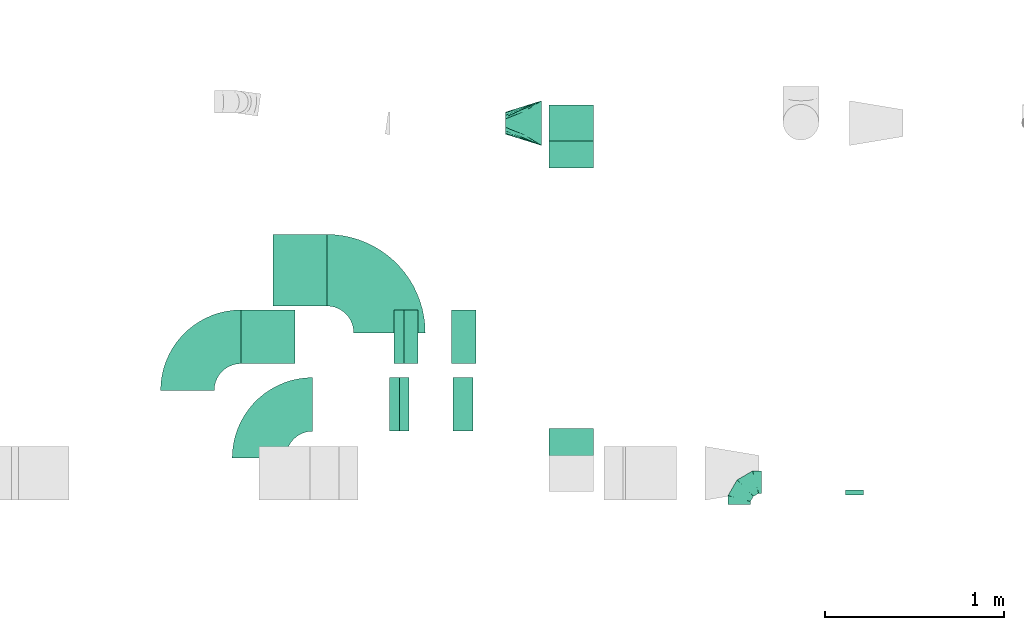
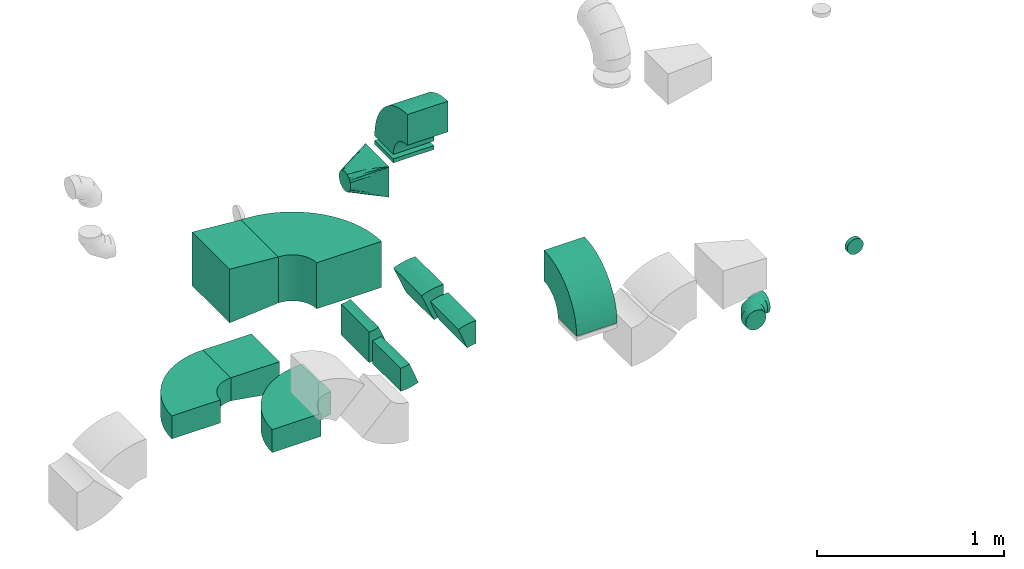
# One storey, part 20 of 44: 15 flow fittings.
"""IFC2X3 building model written with IfcOpenShell, lengths in millimetres."""

from ifc_helpers import new_model, entity, si_unit, converted_unit, derived_unit, direction, frame, frame_2d, origin, origin_2d_with_axis, place, context, subcontext, project, spatial, polyline, circle_curve, parameter, trimmed, segment, composite_curve, rectangle, outline, extrude, faceted_brep, source, transform, mapped, material, type_object, type_shapes, element, save


model = new_model("IFC2X3")

# Units and contexts
model_context = context("Model", 3, precision=0.01, world=origin(), true_north=direction((6.12303176911189e-17, 1.0)))
body_context = subcontext(model_context, "Body", "Model", "MODEL_VIEW")
ifc_project = project(units=[si_unit("LENGTHUNIT", "METRE", prefix="MILLI"), si_unit("AREAUNIT", "SQUARE_METRE"), si_unit("VOLUMEUNIT", "CUBIC_METRE"), converted_unit("PLANEANGLEUNIT", "DEGREE", entity("IfcRatioMeasure", 0.0174532925199433), si_unit("PLANEANGLEUNIT", "RADIAN"), dimensions=[0, 0, 0, 0, 0, 0, 0]), si_unit("MASSUNIT", "GRAM", prefix="KILO"), derived_unit("MASSDENSITYUNIT", [(si_unit("MASSUNIT", "GRAM", prefix="KILO"), 1), (si_unit("LENGTHUNIT", "METRE"), -3)]), derived_unit("MOMENTOFINERTIAUNIT", [(si_unit("LENGTHUNIT", "METRE"), 4)]), si_unit("TIMEUNIT", "SECOND"), si_unit("FREQUENCYUNIT", "HERTZ"), si_unit("THERMODYNAMICTEMPERATUREUNIT", "DEGREE_CELSIUS"), derived_unit("THERMALTRANSMITTANCEUNIT", [(si_unit("MASSUNIT", "GRAM", prefix="KILO"), 1), (si_unit("THERMODYNAMICTEMPERATUREUNIT", "KELVIN"), -1), (si_unit("TIMEUNIT", "SECOND"), -3)]), derived_unit("VOLUMETRICFLOWRATEUNIT", [(si_unit("LENGTHUNIT", "METRE"), 3), (si_unit("TIMEUNIT", "SECOND"), -1)]), derived_unit("MASSFLOWRATEUNIT", [(si_unit("MASSUNIT", "GRAM", prefix="KILO"), 1), (si_unit("TIMEUNIT", "SECOND"), -1)]), derived_unit("ROTATIONALFREQUENCYUNIT", [(si_unit("TIMEUNIT", "SECOND"), -1)]), si_unit("ELECTRICCURRENTUNIT", "AMPERE"), si_unit("ELECTRICVOLTAGEUNIT", "VOLT"), si_unit("POWERUNIT", "WATT"), si_unit("FORCEUNIT", "NEWTON", prefix="KILO"), si_unit("ILLUMINANCEUNIT", "LUX"), si_unit("LUMINOUSFLUXUNIT", "LUMEN"), si_unit("LUMINOUSINTENSITYUNIT", "CANDELA"), derived_unit("USERDEFINED", [(si_unit("MASSUNIT", "GRAM", prefix="KILO"), -1), (si_unit("LENGTHUNIT", "METRE"), -2), (si_unit("TIMEUNIT", "SECOND"), 3), (si_unit("LUMINOUSFLUXUNIT", "LUMEN"), 1)]), derived_unit("LINEARVELOCITYUNIT", [(si_unit("LENGTHUNIT", "METRE"), 1), (si_unit("TIMEUNIT", "SECOND"), -1)]), si_unit("PRESSUREUNIT", "PASCAL"), derived_unit("USERDEFINED", [(si_unit("LENGTHUNIT", "METRE"), -2), (si_unit("MASSUNIT", "GRAM", prefix="KILO"), 1), (si_unit("TIMEUNIT", "SECOND"), -2)]), derived_unit("LINEARFORCEUNIT", [(si_unit("MASSUNIT", "GRAM", prefix="KILO"), 1), (si_unit("LENGTHUNIT", "METRE"), 1), (si_unit("TIMEUNIT", "SECOND"), -2), (si_unit("LENGTHUNIT", "METRE"), -1)]), derived_unit("PLANARFORCEUNIT", [(si_unit("MASSUNIT", "GRAM", prefix="KILO"), 1), (si_unit("LENGTHUNIT", "METRE"), 1), (si_unit("TIMEUNIT", "SECOND"), -2), (si_unit("LENGTHUNIT", "METRE"), -2)])], contexts=[model_context])

# Site, building, storey
site_placement = place(None, origin())
site = spatial("IfcSite", under=ifc_project, at=site_placement, CompositionType="ELEMENT")
building_placement = place(site_placement, origin())
building = spatial("IfcBuilding", under=site, at=building_placement, CompositionType="ELEMENT")
storey_placement = place(building_placement, frame((0.0, 0.0, 15900.0)))
storey = spatial("IfcBuildingStorey", under=building, at=storey_placement, CompositionType="ELEMENT", Elevation=15900.0)

# Flow fittings
ifc_material = material()
duct_fitting_type_1 = type_object("IfcDuctFittingType", PredefinedType="NOTDEFINED", material=ifc_material)
shared_shape_1 = source(origin(), body_context, "Body", "SweptSolid", [
    extrude(outline(polyline([(-150.0, -87.5), (150.0, -87.5), (150.0, 62.5), (-150.0, 112.5), (-150.0, -87.5)])), frame((150.0, -150.0, 12.5), z_axis=(0.0, 1.0, 0.0), x_axis=(1.0, 0.0, 0.0)), (0.0, 0.0, 1.0), 300.0),
])
type_shapes(duct_fitting_type_1, [shared_shape_1])
flow_fitting_1_placement = place(storey_placement, frame((37920.11, 14938.36, 2900.0), z_axis=(0.0, 0.0, 1.0), x_axis=(-1.0, 0.0, 0.0)))
element("IfcFlowFitting", 1, at=flow_fitting_1_placement, inside=storey, type_object=duct_fitting_type_1, material=ifc_material, context=body_context, shape_type="MappedRepresentation", body=[
    mapped(shared_shape_1, transform((0.0, 0.0, 0.0), scale=1.0)),
])
duct_fitting_type_2 = type_object("IfcDuctFittingType", PredefinedType="NOTDEFINED", material=ifc_material)
shared_shape_2 = source(origin(), body_context, "Body", "SweptSolid", [
    extrude(rectangle(XDim=26.096000000009, YDim=250.0, at=origin_2d_with_axis()), frame((6.95, 0.0, -100.0)), (0.0, 0.0, 1.0), 200.0),
])
type_shapes(duct_fitting_type_2, [shared_shape_2])
flow_fitting_2_placement = place(storey_placement, frame((39464.82, 16131.71, 3050.0), z_axis=(0.0, 1.0, 0.0), x_axis=(0.0, 0.0, 1.0)))
element("IfcFlowFitting", 2, at=flow_fitting_2_placement, inside=storey, type_object=duct_fitting_type_2, material=ifc_material, context=body_context, shape_type="MappedRepresentation", body=[
    mapped(shared_shape_2, transform((0.0, 0.0, 0.0), scale=1.0)),
])
duct_fitting_type_3 = type_object("IfcDuctFittingType", PredefinedType="NOTDEFINED", material=ifc_material)
shared_shape_3 = source(origin(), body_context, "Body", "SweptSolid", [
    extrude(outline(polyline([(-137.03, -161.94), (164.01, -161.94), (134.95, 186.85), (-161.94, 137.03), (-137.03, -161.94)])), frame((150.0, -200.0, 0.0), z_axis=(0.0, 1.0, 0.0), x_axis=(0.996545758244888, 0.0, 0.0830454798536443)), (0.0, 0.0, 1.0), 400.0),
])
type_shapes(duct_fitting_type_3, [shared_shape_3])
flow_fitting_3_placement = place(storey_placement, frame((38098.74, 15310.0, 3275.0), z_axis=(0.0, 0.0, 1.0), x_axis=(-1.0, 0.0, 0.0)))
element("IfcFlowFitting", 3, at=flow_fitting_3_placement, inside=storey, type_object=duct_fitting_type_3, material=ifc_material, context=body_context, shape_type="MappedRepresentation", body=[
    mapped(shared_shape_3, transform((0.0, 0.0, 0.0), scale=1.0)),
])
duct_fitting_type_4 = type_object("IfcDuctFittingType", PredefinedType="NOTDEFINED", material=ifc_material)
shared_shape_4 = source(origin(), body_context, "Body", "Brep", [
    faceted_brep([(-125.0, 0.0, -62.5), (-125.0, -16.18, -60.37), (-125.0, -31.25, -54.13), (-125.0, -44.19, -44.19), (-125.0, -54.13, -31.25), (-125.0, -60.37, -16.18), (-125.0, -62.5, 0.0), (-125.0, -60.37, 16.18), (-125.0, -54.13, 31.25), (-125.0, -44.19, 44.19), (-125.0, -31.25, 54.13), (-125.0, -16.18, 60.37), (-125.0, 0.0, 62.5), (-125.0, 16.18, 60.37), (-125.0, 31.25, 54.13), (-125.0, 44.19, 44.19), (-125.0, 54.13, 31.25), (-125.0, 60.37, 16.18), (-125.0, 62.5, 0.0), (-125.0, 60.37, -16.18), (-125.0, 54.13, -31.25), (-125.0, 44.19, -44.19), (-125.0, 31.25, -54.13), (-125.0, 16.18, -60.37), (-95.84, 16.18, 60.37), (-99.88, 31.25, 54.13), (-91.51, 0.0, 62.5), (-103.35, 44.19, 44.19), (-107.68, 60.37, 16.18), (-108.25, 62.5, 0.0), (-106.01, 54.13, 31.25), (-106.01, 54.13, -31.25), (-103.35, 44.19, -44.19), (-107.68, 60.37, -16.18), (-95.84, 16.18, -60.37), (-91.51, 0.0, -62.5), (-99.88, 31.25, -54.13), (-87.17, -16.18, -60.37), (-83.13, -31.25, -54.13), (-79.66, -44.19, -44.19), (-77.0, -54.13, -31.25), (-75.33, -60.37, -16.18), (-74.76, -62.5, 0.0), (-75.33, -60.37, 16.18), (-77.0, -54.13, 31.25), (-79.66, -44.19, 44.19), (-83.13, -31.25, 54.13), (-87.17, -16.18, 60.37), (-45.34, 45.34, 60.37), (-56.37, 56.37, 54.13), (-33.49, 33.49, 62.5), (-65.85, 65.85, 44.19), (-73.12, 73.12, 31.25), (-77.69, 77.69, 16.18), (-79.25, 79.25, 0.0), (-77.69, 77.69, -16.18), (-73.12, 73.12, -31.25), (-65.85, 65.85, -44.19), (-45.34, 45.34, -60.37), (-33.49, 33.49, -62.5), (-56.37, 56.37, -54.13), (-21.65, 21.65, -60.37), (-10.62, 10.62, -54.13), (-1.14, 1.14, -44.19), (6.13, -6.13, -31.25), (10.7, -10.7, -16.18), (12.26, -12.26, 0.0), (10.7, -10.7, 16.18), (6.13, -6.13, 31.25), (-1.14, 1.14, 44.19), (-10.62, 10.62, 54.13), (-21.65, 21.65, 60.37), (-16.18, 95.84, 60.37), (-31.25, 99.88, 54.13), (0.0, 91.51, 62.5), (-44.19, 103.35, 44.19), (-54.13, 106.01, 31.25), (-60.37, 107.68, 16.18), (-62.5, 108.25, 0.0), (-60.37, 107.68, -16.18), (-54.13, 106.01, -31.25), (-44.19, 103.35, -44.19), (-16.18, 95.84, -60.37), (0.0, 91.51, -62.5), (-31.25, 99.88, -54.13), (16.18, 87.17, -60.37), (31.25, 83.13, -54.13), (44.19, 79.66, -44.19), (54.13, 77.0, -31.25), (60.37, 75.33, -16.18), (62.5, 74.76, 0.0), (60.37, 75.33, 16.18), (54.13, 77.0, 31.25), (44.19, 79.66, 44.19), (31.25, 83.13, 54.13), (16.18, 87.17, 60.37), (-16.18, 125.0, -60.37), (-31.25, 125.0, -54.13), (-44.19, 125.0, -44.19), (-54.13, 125.0, -31.25), (-60.37, 125.0, -16.18), (-62.5, 125.0, 0.0), (-60.37, 125.0, 16.18), (-54.13, 125.0, 31.25), (-44.19, 125.0, 44.19), (-31.25, 125.0, 54.13), (-16.18, 125.0, 60.37), (0.0, 125.0, 62.5), (16.18, 125.0, 60.37), (31.25, 125.0, 54.13), (44.19, 125.0, 44.19), (54.13, 125.0, 31.25), (60.37, 125.0, 16.18), (62.5, 125.0, 0.0), (60.37, 125.0, -16.18), (54.13, 125.0, -31.25), (44.19, 125.0, -44.19), (31.25, 125.0, -54.13), (16.18, 125.0, -60.37), (0.0, 125.0, -62.5)], [[[0, 1, 2, 3, 4, 5, 6, 7, 8, 9, 10, 11, 12, 13, 14, 15, 16, 17, 18, 19, 20, 21, 22, 23]], [[24, 25, 14, 13]], [[26, 24, 13, 12]], [[14, 25, 27, 15]], [[28, 29, 18, 17]], [[30, 28, 17, 16]], [[15, 27, 30, 16]], [[20, 31, 32, 21]], [[33, 31, 20, 19]], [[18, 29, 33, 19]], [[34, 35, 0, 23]], [[36, 34, 23, 22]], [[21, 32, 36, 22]], [[1, 0, 35, 37]], [[2, 1, 37, 38]], [[38, 39, 3, 2]], [[5, 4, 40, 41]], [[6, 5, 41, 42]], [[39, 40, 4, 3]], [[6, 42, 43, 7]], [[7, 43, 44, 8]], [[45, 9, 8, 44]], [[9, 45, 46, 10]], [[10, 46, 47, 11]], [[26, 12, 11, 47]], [[48, 49, 25, 24]], [[50, 48, 24, 26]], [[27, 25, 49, 51]], [[52, 53, 28, 30]], [[51, 52, 30, 27]], [[29, 28, 53, 54]], [[55, 56, 31, 33]], [[54, 55, 33, 29]], [[57, 32, 31, 56]], [[58, 59, 35, 34]], [[60, 58, 34, 36]], [[57, 60, 36, 32]], [[37, 35, 59, 61]], [[38, 37, 61, 62]], [[39, 38, 62, 63]], [[41, 40, 64, 65]], [[42, 41, 65, 66]], [[63, 64, 40, 39]], [[43, 42, 66, 67]], [[44, 43, 67, 68]], [[68, 69, 45, 44]], [[46, 45, 69, 70]], [[47, 46, 70, 71]], [[26, 47, 71, 50]], [[72, 73, 49, 48]], [[74, 72, 48, 50]], [[51, 49, 73, 75]], [[76, 77, 53, 52]], [[75, 76, 52, 51]], [[54, 53, 77, 78]], [[79, 80, 56, 55]], [[78, 79, 55, 54]], [[81, 57, 56, 80]], [[82, 83, 59, 58]], [[84, 82, 58, 60]], [[81, 84, 60, 57]], [[61, 59, 83, 85]], [[62, 61, 85, 86]], [[63, 62, 86, 87]], [[65, 64, 88, 89]], [[66, 65, 89, 90]], [[87, 88, 64, 63]], [[67, 66, 90, 91]], [[68, 67, 91, 92]], [[92, 93, 69, 68]], [[70, 69, 93, 94]], [[71, 70, 94, 95]], [[50, 71, 95, 74]], [[96, 97, 98, 99, 100, 101, 102, 103, 104, 105, 106, 107, 108, 109, 110, 111, 112, 113, 114, 115, 116, 117, 118, 119]], [[72, 74, 107, 106]], [[73, 72, 106, 105]], [[75, 73, 105, 104]], [[77, 76, 103, 102]], [[78, 77, 102, 101]], [[75, 104, 103, 76]], [[78, 101, 100, 79]], [[79, 100, 99, 80]], [[80, 99, 98, 81]], [[96, 119, 83, 82]], [[97, 96, 82, 84]], [[84, 81, 98, 97]], [[83, 119, 118, 85]], [[85, 118, 117, 86]], [[116, 87, 86, 117]], [[88, 115, 114, 89]], [[89, 114, 113, 90]], [[115, 88, 87, 116]], [[91, 90, 113, 112]], [[92, 91, 112, 111]], [[111, 110, 93, 92]], [[95, 94, 109, 108]], [[74, 95, 108, 107]], [[110, 109, 94, 93]]]),
])
type_shapes(duct_fitting_type_4, [shared_shape_4])
flow_fitting_4_placement = place(storey_placement, frame((40402.38, 14126.04, 2880.0), z_axis=(0.0, 0.0, 1.0), x_axis=(-1.0, 0.0, 0.0)))
element("IfcFlowFitting", 4, at=flow_fitting_4_placement, inside=storey, type_object=duct_fitting_type_4, material=ifc_material, context=body_context, shape_type="MappedRepresentation", body=[
    mapped(shared_shape_4, transform((0.0, 0.0, 0.0), scale=1.0)),
])
duct_fitting_type_5 = type_object("IfcDuctFittingType", PredefinedType="NOTDEFINED", material=ifc_material)
shared_shape_5 = source(origin(), body_context, "Body", "Brep", [
    faceted_brep([(20.0, 0.0, -50.0), (20.0, 12.94, -48.3), (20.0, 25.0, -43.3), (20.0, 35.36, -35.36), (20.0, 43.3, -25.0), (20.0, 48.3, -12.94), (20.0, 50.0, 0.0), (20.0, 48.3, 12.94), (20.0, 43.3, 25.0), (20.0, 35.36, 35.36), (20.0, 25.0, 43.3), (20.0, 12.94, 48.3), (20.0, 0.0, 50.0), (20.0, -12.94, 48.3), (20.0, -25.0, 43.3), (20.0, -35.36, 35.36), (20.0, -43.3, 25.0), (20.0, -48.3, 12.94), (20.0, -50.0, 0.0), (20.0, -48.3, -12.94), (20.0, -43.3, -25.0), (20.0, -35.36, -35.36), (20.0, -25.0, -43.3), (20.0, -12.94, -48.3), (0.0, 0.0, 50.0), (-6.1, 0.0, 50.0), (-6.1, -12.94, 48.3), (0.0, -12.94, 48.3), (-6.1, -25.0, 43.3), (0.0, -25.0, 43.3), (0.0, -35.36, 35.36), (-6.1, -35.36, 35.36), (0.0, -43.3, 25.0), (-6.1, -43.3, 25.0), (-6.1, -48.3, 12.94), (0.0, -48.3, 12.94), (-6.1, -50.0, 0.0), (0.0, -50.0, 0.0), (-6.1, -48.3, -12.94), (0.0, -48.3, -12.94), (-6.1, -43.3, -25.0), (0.0, -43.3, -25.0), (0.0, -35.36, -35.36), (-6.1, -35.36, -35.36), (0.0, -25.0, -43.3), (-6.1, -25.0, -43.3), (-6.1, -12.94, -48.3), (0.0, -12.94, -48.3), (-6.1, 0.0, -50.0), (0.0, 0.0, -50.0), (-6.1, 12.94, -48.3), (0.0, 12.94, -48.3), (-6.1, 25.0, -43.3), (0.0, 25.0, -43.3), (0.0, 35.36, -35.36), (-6.1, 35.36, -35.36), (0.0, 43.3, -25.0), (-6.1, 43.3, -25.0), (-6.1, 48.3, -12.94), (0.0, 48.3, -12.94), (-6.1, 50.0, 0.0), (0.0, 50.0, 0.0), (-6.1, 48.3, 12.94), (0.0, 48.3, 12.94), (-6.1, 43.3, 25.0), (0.0, 43.3, 25.0), (0.0, 35.36, 35.36), (-6.1, 35.36, 35.36), (0.0, 25.0, 43.3), (-6.1, 25.0, 43.3), (-6.1, 12.94, 48.3), (0.0, 12.94, 48.3)], [[[0, 1, 2, 3, 4, 5, 6, 7, 8, 9, 10, 11, 12, 13, 14, 15, 16, 17, 18, 19, 20, 21, 22, 23]], [[13, 12, 24, 25, 26, 27]], [[14, 13, 27, 26, 28, 29]], [[30, 15, 14, 29, 28, 31]], [[17, 16, 32, 33, 34, 35]], [[18, 17, 35, 34, 36, 37]], [[32, 16, 15, 30, 31, 33]], [[19, 18, 37, 36, 38, 39]], [[20, 19, 39, 38, 40, 41]], [[42, 21, 20, 41, 40, 43]], [[23, 22, 44, 45, 46, 47]], [[0, 23, 47, 46, 48, 49]], [[44, 22, 21, 42, 43, 45]], [[1, 0, 49, 48, 50, 51]], [[2, 1, 51, 50, 52, 53]], [[54, 3, 2, 53, 52, 55]], [[5, 4, 56, 57, 58, 59]], [[6, 5, 59, 58, 60, 61]], [[56, 4, 3, 54, 55, 57]], [[7, 6, 61, 60, 62, 63]], [[8, 7, 63, 62, 64, 65]], [[66, 9, 8, 65, 64, 67]], [[11, 10, 68, 69, 70, 71]], [[12, 11, 71, 70, 25, 24]], [[68, 10, 9, 66, 67, 69]], [[46, 45, 43, 40, 38, 36, 34, 33, 31, 28, 26, 25, 70, 69, 67, 64, 62, 60, 58, 57, 55, 52, 50, 48]]]),
])
type_shapes(duct_fitting_type_5, [shared_shape_5])
flow_fitting_5_placement = place(storey_placement, frame((41046.31, 14075.53, 3100.0), z_axis=(0.0, 0.0, -1.0), x_axis=(0.0, -1.0, 0.0)))
element("IfcFlowFitting", 5, at=flow_fitting_5_placement, inside=storey, type_object=duct_fitting_type_5, material=ifc_material, context=body_context, shape_type="MappedRepresentation", body=[
    mapped(shared_shape_5, transform((0.0, 0.0, 0.0), scale=1.0)),
])
duct_fitting_type_6 = type_object("IfcDuctFittingType", PredefinedType="NOTDEFINED", material=ifc_material)
shared_shape_6 = source(origin(), body_context, "Body", "Brep", [
    faceted_brep([(200.0, -3.39, 61.83), (200.0, -6.78, 61.15), (200.0, -13.56, 59.8), (200.0, -18.74, 58.77), (200.0, -23.92, 57.74), (200.0, -28.99, 54.36), (200.0, -34.06, 50.97), (200.0, -39.13, 47.58), (200.0, -44.19, 44.19), (200.0, -47.58, 39.13), (200.0, -50.97, 34.06), (200.0, -54.36, 28.99), (200.0, -57.74, 23.92), (200.0, -58.77, 18.74), (200.0, -59.8, 13.56), (200.0, -61.15, 6.78), (200.0, -61.83, 3.39), (200.0, -62.5, 0.0), (200.0, -61.83, -3.39), (200.0, -61.15, -6.78), (200.0, -59.8, -13.56), (200.0, -58.77, -18.74), (200.0, -57.74, -23.92), (200.0, -54.36, -28.99), (200.0, -50.97, -34.06), (200.0, -47.58, -39.13), (200.0, -44.19, -44.19), (200.0, -39.13, -47.58), (200.0, -34.06, -50.97), (200.0, -28.99, -54.36), (200.0, -23.92, -57.74), (200.0, -18.74, -58.77), (200.0, -13.56, -59.8), (200.0, -6.78, -61.15), (200.0, -3.39, -61.83), (200.0, 0.0, -62.5), (200.0, 3.39, -61.83), (200.0, 6.78, -61.15), (200.0, 13.56, -59.8), (200.0, 18.74, -58.77), (200.0, 23.92, -57.74), (200.0, 28.99, -54.36), (200.0, 34.06, -50.97), (200.0, 39.13, -47.58), (200.0, 44.19, -44.19), (200.0, 47.58, -39.13), (200.0, 50.97, -34.06), (200.0, 54.36, -28.99), (200.0, 57.74, -23.92), (200.0, 58.77, -18.74), (200.0, 59.8, -13.56), (200.0, 61.15, -6.78), (200.0, 61.83, -3.39), (200.0, 62.5, 0.0), (200.0, 61.83, 3.39), (200.0, 61.15, 6.78), (200.0, 59.8, 13.56), (200.0, 58.77, 18.74), (200.0, 57.74, 23.92), (200.0, 54.36, 28.99), (200.0, 50.97, 34.06), (200.0, 47.58, 39.13), (200.0, 44.19, 44.19), (200.0, 39.13, 47.58), (200.0, 34.06, 50.97), (200.0, 28.99, 54.36), (200.0, 23.92, 57.74), (200.0, 18.74, 58.77), (200.0, 13.56, 59.8), (200.0, 6.78, 61.15), (200.0, 3.39, 61.83), (200.0, 0.0, 62.5), (0.0, -125.0, 100.0), (0.0, 125.0, 100.0), (0.0, 125.0, -100.0), (0.0, -125.0, -100.0), (100.0, -86.66, 69.82), (22.72, -117.9, 88.64), (45.45, -110.8, 77.28), (90.89, -96.6, 54.55), (145.45, -34.1, 72.73), (118.17, -51.14, 77.84), (104.53, -59.67, 80.4), (90.89, -68.19, 82.96), (186.36, -8.52, 65.06), (172.72, -17.05, 67.61), (118.17, -88.07, 40.92), (145.45, -79.55, 27.28), (172.72, -71.02, 13.64), (186.36, -66.76, 6.82), (110.71, -74.98, 73.44), (68.17, -82.39, 87.22), (45.45, -96.6, 91.48), (22.72, -110.8, 95.74), (68.17, -103.7, 65.92), (22.72, -117.9, -88.64), (45.45, -110.8, -77.28), (68.17, -103.7, -65.92), (90.89, -96.6, -54.55), (104.53, -92.33, -47.73), (118.17, -88.07, -40.92), (145.45, -79.55, -27.28), (172.72, -71.02, -13.64), (186.36, -66.76, -6.82), (100.0, -82.32, -74.16), (22.72, -110.8, -95.74), (45.45, -96.6, -91.48), (90.89, -68.19, -82.96), (118.17, -51.14, -77.84), (145.45, -34.1, -72.73), (172.72, -17.05, -67.61), (186.36, -8.52, -65.06), (110.71, -84.61, -63.81), (68.17, -82.39, -87.22), (22.72, 110.8, -95.74), (45.45, 96.6, -91.48), (68.17, 82.39, -87.22), (90.89, 68.19, -82.96), (104.53, 59.67, -80.4), (118.17, 51.14, -77.84), (145.45, 34.1, -72.73), (172.72, 17.05, -67.61), (186.36, 8.52, -65.06), (100.0, 86.66, -69.82), (22.72, 117.9, -88.64), (45.45, 110.8, -77.28), (90.89, 96.6, -54.55), (118.17, 88.07, -40.92), (145.45, 79.55, -27.28), (172.72, 71.02, -13.64), (186.36, 66.76, -6.82), (110.71, 74.98, -73.44), (68.17, 103.7, -65.92), (22.72, 117.9, 88.64), (45.45, 110.8, 77.28), (68.17, 103.7, 65.92), (90.89, 96.6, 54.55), (104.53, 92.33, 47.73), (118.17, 88.07, 40.92), (145.45, 79.55, 27.28), (172.72, 71.02, 13.64), (186.36, 66.76, 6.82), (100.0, 82.32, 74.16), (22.72, 110.8, 95.74), (45.45, 96.6, 91.48), (90.89, 68.19, 82.96), (118.17, 51.14, 77.84), (145.45, 34.1, 72.73), (172.72, 17.05, 67.61), (186.36, 8.52, 65.06), (110.71, 84.61, 63.81), (68.17, 82.39, 87.22)], [[[0, 1, 2, 3, 4, 5, 6, 7, 8, 9, 10, 11, 12, 13, 14, 15, 16, 17, 18, 19, 20, 21, 22, 23, 24, 25, 26, 27, 28, 29, 30, 31, 32, 33, 34, 35, 36, 37, 38, 39, 40, 41, 42, 43, 44, 45, 46, 47, 48, 49, 50, 51, 52, 53, 54, 55, 56, 57, 58, 59, 60, 61, 62, 63, 64, 65, 66, 67, 68, 69, 70, 71]], [[72, 73, 74, 75]], [[76, 72, 77, 78]], [[79, 12, 11]], [[80, 81, 82, 83, 4, 3, 2, 1, 0, 71, 84, 85]], [[12, 79, 86, 87, 88, 89, 17, 16, 15, 14, 13]], [[7, 6, 90, 8]], [[90, 76, 8]], [[91, 92, 6]], [[90, 92, 93]], [[76, 9, 8]], [[10, 94, 11]], [[78, 10, 9]], [[93, 72, 76]], [[94, 10, 78]], [[78, 9, 76]], [[76, 90, 93]], [[6, 5, 91]], [[5, 4, 83]], [[5, 83, 91]], [[92, 90, 6]], [[94, 79, 11]], [[89, 88, 87, 86, 79, 94, 78, 77, 72, 75, 95, 96, 97, 98, 99, 100, 101, 102, 103, 17]], [[104, 75, 105, 106]], [[107, 30, 29]], [[101, 100, 99, 98, 22, 21, 20, 19, 18, 17, 103, 102]], [[30, 107, 108, 109, 110, 111, 35, 34, 33, 32, 31]], [[25, 24, 112, 26]], [[112, 104, 26]], [[97, 96, 24]], [[112, 96, 95]], [[104, 27, 26]], [[28, 113, 29]], [[106, 28, 27]], [[95, 75, 104]], [[113, 28, 106]], [[106, 27, 104]], [[104, 112, 95]], [[24, 23, 97]], [[23, 22, 98]], [[23, 98, 97]], [[96, 112, 24]], [[113, 107, 29]], [[111, 110, 109, 108, 107, 113, 106, 105, 75, 74, 114, 115, 116, 117, 118, 119, 120, 121, 122, 35]], [[123, 74, 124, 125]], [[126, 48, 47]], [[120, 119, 118, 117, 40, 39, 38, 37, 36, 35, 122, 121]], [[48, 126, 127, 128, 129, 130, 53, 52, 51, 50, 49]], [[43, 42, 131, 44]], [[131, 123, 44]], [[116, 115, 42]], [[131, 115, 114]], [[123, 45, 44]], [[46, 132, 47]], [[125, 46, 45]], [[114, 74, 123]], [[132, 46, 125]], [[125, 45, 123]], [[123, 131, 114]], [[42, 41, 116]], [[41, 40, 117]], [[41, 117, 116]], [[115, 131, 42]], [[132, 126, 47]], [[74, 73, 133, 134, 135, 136, 137, 138, 139, 140, 141, 53, 130, 129, 128, 127, 126, 132, 125, 124]], [[142, 73, 143, 144]], [[145, 66, 65]], [[139, 138, 137, 136, 58, 57, 56, 55, 54, 53, 141, 140]], [[66, 145, 146, 147, 148, 149, 71, 70, 69, 68, 67]], [[61, 60, 150, 62]], [[150, 142, 62]], [[135, 134, 60]], [[150, 134, 133]], [[142, 63, 62]], [[64, 151, 65]], [[144, 64, 63]], [[133, 73, 142]], [[151, 64, 144]], [[144, 63, 142]], [[142, 150, 133]], [[60, 59, 135]], [[59, 58, 136]], [[59, 136, 135]], [[134, 150, 60]], [[151, 145, 65]], [[73, 72, 93, 92, 91, 83, 82, 81, 80, 85, 84, 71, 149, 148, 147, 146, 145, 151, 144, 143]]]),
])
type_shapes(duct_fitting_type_6, [shared_shape_6])
flow_fitting_6_placement = place(storey_placement, frame((39298.08, 16131.51, 2950.0), z_axis=(0.0, 0.0, 1.0), x_axis=(-1.0, 0.0, 0.0)))
element("IfcFlowFitting", 6, at=flow_fitting_6_placement, inside=storey, type_object=duct_fitting_type_6, material=ifc_material, context=body_context, shape_type="MappedRepresentation", body=[
    mapped(shared_shape_6, transform((0.0, 0.0, 0.0), scale=1.0)),
])
duct_fitting_type_7 = type_object("IfcDuctFittingType", PredefinedType="NOTDEFINED", material=ifc_material)
shared_shape_7 = source(origin(), body_context, "Body", "SweptSolid", [
    extrude(outline(composite_curve([segment(polyline([(-300.0, -150.0), (0.0, -150.0)]), True, "CONTINUOUS"), segment(trimmed(circle_curve(frame_2d((150.0, -150.0), x_axis=(0.0, 1.0)), 150.0), [parameter(0.0)], [parameter(90.0)], True, "PARAMETER"), False, "CONTINUOUS"), segment(polyline([(150.0, 0.0), (150.0, 300.0)]), True, "CONTINUOUS"), segment(trimmed(circle_curve(frame_2d((150.0, -150.0), x_axis=(0.0, 1.0)), 450.0), [parameter(0.0)], [parameter(90.0000000000001)], True, "PARAMETER"), True, "CONTINUOUS")], self_intersect=False)), frame((-150.0, 150.0, -75.0), z_axis=(0.0, 0.0, 1.0), x_axis=(-1.0, 0.0, 0.0)), (0.0, 0.0, 1.0), 150.0),
])
type_shapes(duct_fitting_type_7, [shared_shape_7])
for number, where, z_axis, x_axis in (
    (7, (37720.04, 14560.54, 2925.0), (0.0, 0.0, 1.0), (-1.0, 0.0, 0.0)),
    (8, (37320.11, 14938.36, 2925.0), (0.0, 0.0, 1.0), (-1.0, 0.0, 0.0)),
):
    element("IfcFlowFitting", number, at=place(storey_placement, frame(where, z_axis=z_axis, x_axis=x_axis)), inside=storey, type_object=duct_fitting_type_7, material=ifc_material, context=body_context, shape_type="MappedRepresentation", body=[
        mapped(shared_shape_7, transform((0.0, 0.0, 0.0), scale=1.0)),
    ])
duct_fitting_type_8 = type_object("IfcDuctFittingType", PredefinedType="NOTDEFINED", material=ifc_material)
shared_shape_8 = source(origin(), body_context, "Body", "SweptSolid", [
    extrude(outline(composite_curve([segment(polyline([(-225.0, -125.0), (-25.0, -125.0)]), True, "CONTINUOUS"), segment(trimmed(circle_curve(frame_2d((125.0, -125.0), x_axis=(0.0, 1.0)), 150.0), [parameter(0.0)], [parameter(90.0)], True, "PARAMETER"), False, "CONTINUOUS"), segment(polyline([(125.0, 25.0), (125.0, 225.0)]), True, "CONTINUOUS"), segment(trimmed(circle_curve(frame_2d((125.0, -125.0), x_axis=(0.0, 1.0)), 350.0), [parameter(0.0)], [parameter(90.0)], True, "PARAMETER"), True, "CONTINUOUS")], self_intersect=False)), frame((-125.0, 125.0, -125.0), z_axis=(0.0, 0.0, 1.0), x_axis=(-1.0, 0.0, 0.0)), (0.0, 0.0, 1.0), 250.0),
])
type_shapes(duct_fitting_type_8, [shared_shape_8])
for number, where, z_axis, x_axis in (
    (9, (39464.82, 16131.71, 3350.0), (-1.0, 0.0, 0.0), (0.0, 1.0, 0.0)),
    (10, (39464.82, 14174.64, 3350.0), (1.0, 0.0, 0.0), (0.0, -1.0, 0.0)),
):
    element("IfcFlowFitting", number, at=place(storey_placement, frame(where, z_axis=z_axis, x_axis=x_axis)), inside=storey, type_object=duct_fitting_type_8, material=ifc_material, context=body_context, shape_type="MappedRepresentation", body=[
        mapped(shared_shape_8, transform((0.0, 0.0, 0.0), scale=1.0)),
    ])
duct_fitting_type_9 = type_object("IfcDuctFittingType", PredefinedType="NOTDEFINED", material=ifc_material)
shared_shape_9 = source(origin(), body_context, "Body", "SweptSolid", [
    extrude(outline(composite_curve([segment(polyline([(-375.0, -175.0), (25.0, -175.0)]), True, "CONTINUOUS"), segment(trimmed(circle_curve(frame_2d((175.0, -175.0), x_axis=(0.0, 1.0)), 150.0), [parameter(0.0)], [parameter(90.0000000000001)], True, "PARAMETER"), False, "CONTINUOUS"), segment(polyline([(175.0, -25.0), (175.0, 375.0)]), True, "CONTINUOUS"), segment(trimmed(circle_curve(frame_2d((175.0, -175.0), x_axis=(0.0, 1.0)), 550.0), [parameter(0.0)], [parameter(90.0)], True, "PARAMETER"), True, "CONTINUOUS")], self_intersect=False)), frame((-175.0, 175.0, -150.0), z_axis=(0.0, 0.0, 1.0), x_axis=(-1.0, 0.0, 0.0)), (0.0, 0.0, 1.0), 300.0),
])
type_shapes(duct_fitting_type_9, [shared_shape_9])
flow_fitting_7_placement = place(storey_placement, frame((38448.74, 15310.0, 3275.0), z_axis=(0.0, 0.0, 1.0), x_axis=(0.0, 1.0, 0.0)))
element("IfcFlowFitting", 11, at=flow_fitting_7_placement, inside=storey, type_object=duct_fitting_type_9, material=ifc_material, context=body_context, shape_type="MappedRepresentation", body=[
    mapped(shared_shape_9, transform((0.0, 0.0, 0.0), scale=1.0)),
])
duct_fitting_type_10 = type_object("IfcDuctFittingType", PredefinedType="NOTDEFINED", material=ifc_material)
shared_shape_10 = source(origin(), body_context, "Body", "SweptSolid", [
    extrude(outline(composite_curve([segment(polyline([(-82.84, -41.27), (67.16, -41.27)]), True, "CONTINUOUS"), segment(trimmed(circle_curve(frame_2d((217.16, -41.27), x_axis=(-0.930282021712747, 0.366845144547453)), 150.0), [parameter(0.0)], [parameter(21.5211802481722)], True, "PARAMETER"), False, "CONTINUOUS"), segment(polyline([(77.61, 13.76), (-61.93, 68.78)]), True, "CONTINUOUS"), segment(trimmed(circle_curve(frame_2d((217.16, -41.27), x_axis=(-0.930282021712747, 0.366845144547453)), 300.0), [parameter(0.0)], [parameter(21.5211802481722)], True, "PARAMETER"), True, "CONTINUOUS")], self_intersect=False)), frame((-1.49, 7.84, -150.0), z_axis=(0.0, 0.0, 1.0), x_axis=(-0.366845144547453, 0.930282021712748, 0.0)), (0.0, 0.0, 1.0), 300.0),
])
type_shapes(duct_fitting_type_10, [shared_shape_10])
for number, where, z_axis, x_axis in (
    (12, (38871.82, 14560.54, 3075.0), (0.0, -1.0, 0.0), (-1.0, 0.0, 0.0)),
    (13, (38491.43, 14560.54, 2925.0), (0.0, -1.0, 0.0), (1.0, 0.0, 0.0)),
):
    element("IfcFlowFitting", number, at=place(storey_placement, frame(where, z_axis=z_axis, x_axis=x_axis)), inside=storey, type_object=duct_fitting_type_10, material=ifc_material, context=body_context, shape_type="MappedRepresentation", body=[
        mapped(shared_shape_10, transform((0.0, 0.0, 0.0), scale=1.0)),
    ])
duct_fitting_type_11 = type_object("IfcDuctFittingType", PredefinedType="NOTDEFINED", material=ifc_material)
shared_shape_11 = source(origin(), body_context, "Body", "SweptSolid", [
    extrude(outline(composite_curve([segment(polyline([(-109.75, -48.41), (90.25, -48.41)]), True, "CONTINUOUS"), segment(trimmed(circle_curve(frame_2d((240.25, -48.41), x_axis=(-0.921968138776245, 0.387265737035261)), 150.0), [parameter(0.0)], [parameter(22.7844722051459)], True, "PARAMETER"), False, "CONTINUOUS"), segment(polyline([(101.95, 9.68), (-82.44, 87.13)]), True, "CONTINUOUS"), segment(trimmed(circle_curve(frame_2d((240.25, -48.41), x_axis=(-0.921968138776245, 0.387265737035261)), 350.0), [parameter(0.0)], [parameter(22.7844722051459)], True, "PARAMETER"), True, "CONTINUOUS")], self_intersect=False)), frame((-1.97, 9.75, -150.0), z_axis=(0.0, 0.0, 1.0), x_axis=(-0.387265737035261, 0.921968138776246, 0.0)), (0.0, 0.0, 1.0), 300.0),
])
type_shapes(duct_fitting_type_11, [shared_shape_11])
for number, where, z_axis, x_axis in (
    (14, (38880.7, 14938.36, 3050.0), (0.0, -1.0, 0.0), (-1.0, 0.0, 0.0)),
    (15, (38523.59, 14938.36, 2900.0), (0.0, -1.0, 0.0), (1.0, 0.0, 0.0)),
):
    element("IfcFlowFitting", number, at=place(storey_placement, frame(where, z_axis=z_axis, x_axis=x_axis)), inside=storey, type_object=duct_fitting_type_11, material=ifc_material, context=body_context, shape_type="MappedRepresentation", body=[
        mapped(shared_shape_11, transform((0.0, 0.0, 0.0), scale=1.0)),
    ])

save(model, "model.ifc")
